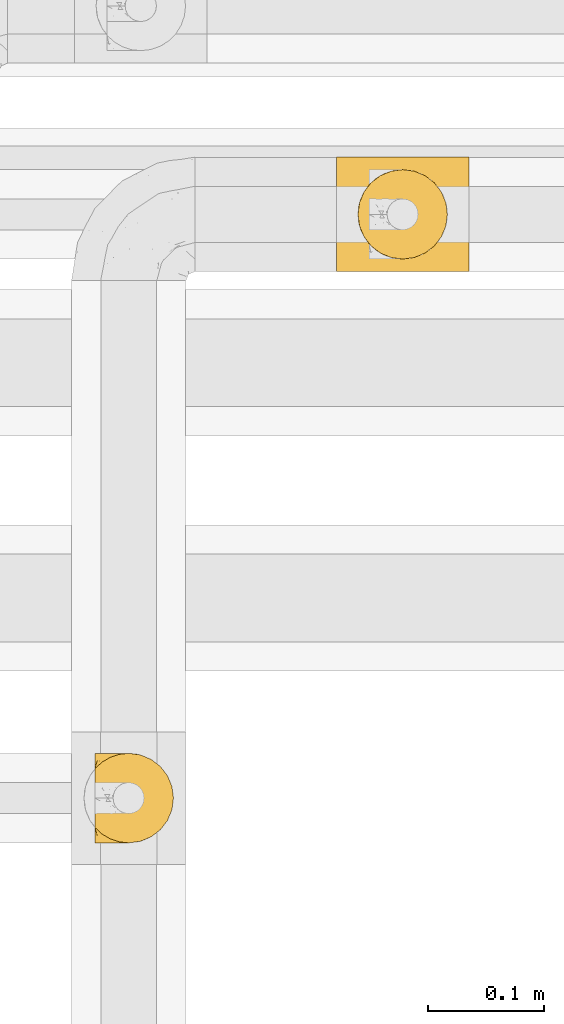
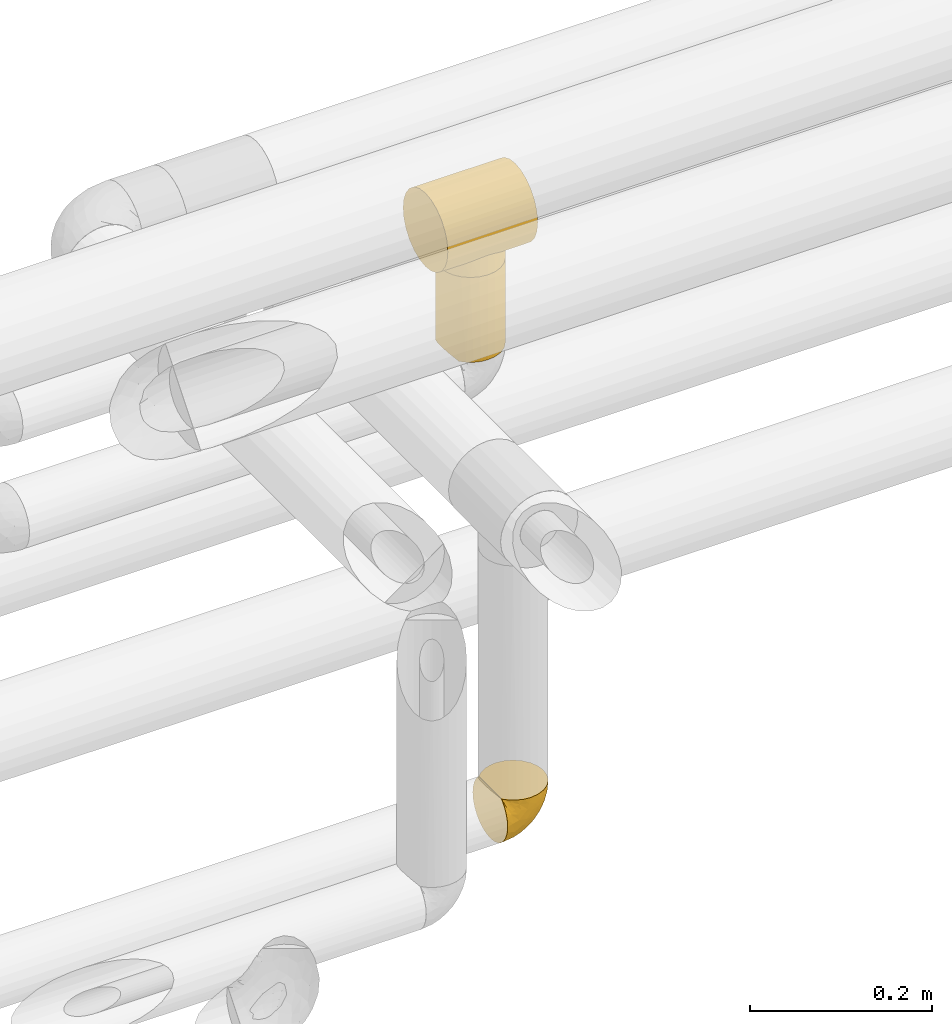
# One storey, part 365 of 827: 3 coverings.
"""IFC2X3 building model written with IfcOpenShell, lengths in millimetres."""

from ifc_helpers import new_model, entity, si_unit, converted_unit, derived_unit, direction, frame, origin, place, context, subcontext, project, spatial, faceted_brep, element, save


model = new_model("IFC2X3")

# Units and contexts
model_context = context("Model", 3, precision=0.01, world=origin(), true_north=direction((6.12303176911189e-17, 1.0)))
body_context = subcontext(model_context, "Body", "Model", "MODEL_VIEW")
ifc_project = project(units=[si_unit("LENGTHUNIT", "METRE", prefix="MILLI"), si_unit("AREAUNIT", "SQUARE_METRE"), si_unit("VOLUMEUNIT", "CUBIC_METRE"), converted_unit("PLANEANGLEUNIT", "DEGREE", entity("IfcRatioMeasure", 0.0174532925199433), si_unit("PLANEANGLEUNIT", "RADIAN"), dimensions=[0, 0, 0, 0, 0, 0, 0]), si_unit("MASSUNIT", "GRAM", prefix="KILO"), derived_unit("MASSDENSITYUNIT", [(si_unit("MASSUNIT", "GRAM", prefix="KILO"), 1), (si_unit("LENGTHUNIT", "METRE"), -3)]), derived_unit("MOMENTOFINERTIAUNIT", [(si_unit("LENGTHUNIT", "METRE"), 4)]), si_unit("TIMEUNIT", "SECOND"), si_unit("FREQUENCYUNIT", "HERTZ"), si_unit("THERMODYNAMICTEMPERATUREUNIT", "DEGREE_CELSIUS"), derived_unit("THERMALTRANSMITTANCEUNIT", [(si_unit("MASSUNIT", "GRAM", prefix="KILO"), 1), (si_unit("THERMODYNAMICTEMPERATUREUNIT", "KELVIN"), -1), (si_unit("TIMEUNIT", "SECOND"), -3)]), derived_unit("VOLUMETRICFLOWRATEUNIT", [(si_unit("LENGTHUNIT", "METRE"), 3), (si_unit("TIMEUNIT", "SECOND"), -1)]), derived_unit("MASSFLOWRATEUNIT", [(si_unit("MASSUNIT", "GRAM", prefix="KILO"), 1), (si_unit("TIMEUNIT", "SECOND"), -1)]), derived_unit("ROTATIONALFREQUENCYUNIT", [(si_unit("TIMEUNIT", "SECOND"), -1)]), si_unit("ELECTRICCURRENTUNIT", "AMPERE"), si_unit("ELECTRICVOLTAGEUNIT", "VOLT"), si_unit("POWERUNIT", "WATT"), si_unit("FORCEUNIT", "NEWTON", prefix="KILO"), si_unit("ILLUMINANCEUNIT", "LUX"), si_unit("LUMINOUSFLUXUNIT", "LUMEN"), si_unit("LUMINOUSINTENSITYUNIT", "CANDELA"), derived_unit("USERDEFINED", [(si_unit("MASSUNIT", "GRAM", prefix="KILO"), -1), (si_unit("LENGTHUNIT", "METRE"), -2), (si_unit("TIMEUNIT", "SECOND"), 3), (si_unit("LUMINOUSFLUXUNIT", "LUMEN"), 1)]), derived_unit("LINEARVELOCITYUNIT", [(si_unit("LENGTHUNIT", "METRE"), 1), (si_unit("TIMEUNIT", "SECOND"), -1)]), si_unit("PRESSUREUNIT", "PASCAL"), derived_unit("USERDEFINED", [(si_unit("LENGTHUNIT", "METRE"), -2), (si_unit("MASSUNIT", "GRAM", prefix="KILO"), 1), (si_unit("TIMEUNIT", "SECOND"), -2)]), derived_unit("LINEARFORCEUNIT", [(si_unit("MASSUNIT", "GRAM", prefix="KILO"), 1), (si_unit("LENGTHUNIT", "METRE"), 1), (si_unit("TIMEUNIT", "SECOND"), -2), (si_unit("LENGTHUNIT", "METRE"), -1)]), derived_unit("PLANARFORCEUNIT", [(si_unit("MASSUNIT", "GRAM", prefix="KILO"), 1), (si_unit("LENGTHUNIT", "METRE"), 1), (si_unit("TIMEUNIT", "SECOND"), -2), (si_unit("LENGTHUNIT", "METRE"), -2)])], contexts=[model_context])

# Site, building, storey
site_placement = place(None, origin())
site = spatial("IfcSite", under=ifc_project, at=site_placement, CompositionType="ELEMENT")
building_placement = place(site_placement, origin())
building = spatial("IfcBuilding", under=site, at=building_placement, CompositionType="ELEMENT")
storey_placement = place(building_placement, frame((0.0, 0.0, 28200.0)))
storey = spatial("IfcBuildingStorey", under=building, at=storey_placement, Name="08", CompositionType="ELEMENT", Elevation=28200.0)

# Coverings
covering_1_placement = place(storey_placement, frame((36825.03, 18896.41, 3227.5)))
element("IfcCovering", 1, at=covering_1_placement, inside=storey, Name=":ADSK_", ObjectType=":ADSK_", PredefinedType="INSULATION", context=body_context, shape_type="Brep", body=[
    faceted_brep([(77.09, 30.06, 115.39), (78.4, 40.0, 115.39), (77.09, 49.93, 115.39), (73.25, 59.2, 115.39), (67.15, 67.15, 115.39), (59.2, 73.25, 115.39), (49.93, 77.09, 115.39), (40.0, 78.4, 115.39), (30.06, 77.09, 115.39), (20.8, 73.25, 115.39), (12.84, 67.15, 115.39), (6.74, 59.2, 115.39), (2.9, 49.93, 115.39), (1.6, 40.0, 115.39), (2.9, 30.06, 115.39), (6.74, 20.8, 115.39), (12.84, 12.84, 115.39), (20.8, 6.74, 115.39), (30.06, 2.9, 115.39), (40.0, 1.6, 115.39), (49.93, 2.9, 115.39), (59.2, 6.74, 115.39), (67.15, 12.84, 115.39), (73.25, 20.8, 115.39), (78.4, 40.0, 1.6), (77.09, 30.06, 1.6), (73.25, 20.8, 1.6), (67.15, 12.84, 1.6), (59.2, 6.74, 1.6), (49.93, 2.9, 1.6), (40.0, 1.6, 1.6), (31.79, 2.48, 1.6), (23.98, 5.09, 1.6), (16.91, 9.31, 1.6), (10.9, 14.94, 1.6), (10.9, 65.05, 1.6), (16.91, 70.68, 1.6), (23.98, 74.9, 1.6), (31.79, 77.51, 1.6), (40.0, 78.4, 1.6), (49.93, 77.09, 1.6), (59.2, 73.25, 1.6), (67.15, 67.15, 1.6), (73.25, 59.2, 1.6), (77.09, 49.93, 1.6), (6.92, 59.51, 5.57), (4.0, 53.36, 8.5), (2.2, 46.78, 10.29), (1.6, 40.0, 10.9), (2.2, 33.21, 10.29), (4.0, 26.63, 8.5), (6.92, 20.48, 5.57)], [[[0, 1, 2, 3, 4, 5, 6, 7, 8, 9, 10, 11, 12, 13, 14, 15, 16, 17, 18, 19, 20, 21, 22, 23]], [[24, 25, 26, 27, 28, 29, 30, 31, 32, 33, 34, 35, 36, 37, 38, 39, 40, 41, 42, 43, 44]], [[29, 28, 21, 20]], [[30, 29, 20, 19]], [[28, 27, 22, 21]], [[0, 23, 26, 25]], [[1, 0, 25, 24]], [[27, 26, 23, 22]], [[2, 1, 24, 44]], [[3, 2, 44, 43]], [[43, 42, 4, 3]], [[6, 5, 41, 40]], [[7, 6, 40, 39]], [[42, 41, 5, 4]], [[7, 39, 38]], [[8, 38, 37]], [[9, 37, 36]], [[7, 38, 8]], [[8, 37, 9]], [[36, 10, 9]], [[36, 35, 10]], [[35, 45, 11]], [[46, 47, 12]], [[45, 46, 11]], [[11, 46, 12]], [[13, 12, 47]], [[48, 13, 47]], [[35, 11, 10]], [[49, 50, 14]], [[51, 34, 15]], [[50, 51, 15]], [[48, 49, 13]], [[13, 49, 14]], [[50, 15, 14]], [[34, 16, 15]], [[17, 33, 32]], [[18, 32, 31]], [[19, 31, 30]], [[16, 33, 17]], [[17, 32, 18]], [[31, 19, 18]], [[33, 16, 34]], [[47, 46, 45, 35, 34, 51, 50, 49, 48]]]),
])
covering_2_placement = place(storey_placement, frame((36808.02, 18885.66, 3342.89)))
element("IfcCovering", 2, at=covering_2_placement, inside=storey, Name=":ADSK_", ObjectType=":ADSK_", PredefinedType="INSULATION", context=body_context, shape_type="Brep", body=[
    faceted_brep([(0.0, 26.17, 99.57), (0.0, 38.02, 104.48), (0.0, 50.75, 106.15), (0.0, 63.47, 104.48), (0.0, 75.32, 99.57), (0.0, 85.5, 91.75), (0.0, 93.31, 81.58), (0.0, 98.22, 69.72), (0.0, 99.9, 57.0), (0.0, 98.22, 44.28), (0.0, 93.31, 32.43), (0.0, 85.5, 22.25), (0.0, 80.41, 18.34), (0.0, 75.32, 14.43), (0.0, 69.39, 11.98), (0.0, 63.47, 9.52), (0.0, 60.29, 9.11), (0.0, 57.11, 8.69), (0.0, 53.93, 8.27), (0.0, 50.75, 7.85), (0.0, 47.57, 8.27), (0.0, 44.38, 8.69), (0.0, 41.2, 9.11), (0.0, 38.02, 9.52), (0.0, 32.1, 11.98), (0.0, 26.17, 14.43), (0.0, 21.08, 18.34), (0.0, 15.99, 22.25), (0.0, 8.18, 32.43), (0.0, 3.27, 44.28), (0.0, 1.6, 57.0), (0.0, 3.27, 69.72), (0.0, 8.18, 81.58), (0.0, 15.99, 91.75), (114.0, 98.22, 69.72), (114.0, 93.31, 81.58), (114.0, 85.5, 91.75), (114.0, 75.32, 99.57), (114.0, 63.47, 104.48), (114.0, 50.75, 106.15), (114.0, 38.02, 104.48), (114.0, 26.17, 99.57), (114.0, 15.99, 91.75), (114.0, 8.18, 81.58), (114.0, 3.27, 69.72), (114.0, 1.6, 57.0), (114.0, 3.27, 44.28), (114.0, 8.18, 32.43), (114.0, 15.99, 22.25), (114.0, 21.08, 18.34), (114.0, 26.17, 14.43), (114.0, 32.1, 11.98), (114.0, 38.02, 9.52), (114.0, 41.2, 9.11), (114.0, 44.38, 8.69), (114.0, 47.57, 8.27), (114.0, 50.75, 7.85), (114.0, 53.93, 8.27), (114.0, 57.11, 8.69), (114.0, 60.29, 9.11), (114.0, 63.47, 9.52), (114.0, 69.39, 11.98), (114.0, 75.32, 14.43), (114.0, 80.41, 18.34), (114.0, 85.5, 22.25), (114.0, 93.31, 32.43), (114.0, 98.22, 44.28), (114.0, 99.9, 57.0), (80.91, 80.86, 18.16), (73.95, 85.26, 22.01), (86.77, 75.08, 14.3), (22.63, 67.99, 10.97), (65.92, 88.15, 25.11), (57.0, 89.2, 26.38), (48.08, 88.15, 25.11), (18.55, 50.75, 7.85), (95.45, 50.75, 7.85), (33.09, 80.86, 18.16), (40.05, 85.26, 22.01), (27.23, 75.08, 14.3), (91.37, 67.99, 10.97), (21.12, 63.86, 9.83), (94.39, 59.73, 8.68), (94.92, 55.24, 8.26), (92.88, 63.86, 9.83), (19.61, 59.73, 8.68), (19.08, 55.24, 8.26), (94.92, 46.25, 8.26), (92.88, 37.63, 9.83), (86.77, 26.41, 14.3), (94.39, 41.76, 8.68), (91.37, 33.5, 10.97), (21.12, 37.63, 9.83), (19.61, 41.76, 8.68), (19.08, 46.25, 8.26), (27.23, 26.41, 14.3), (22.63, 33.5, 10.97), (33.09, 20.63, 18.16), (80.91, 20.63, 18.16), (73.95, 16.23, 22.01), (65.92, 13.34, 25.11), (57.0, 12.3, 26.38), (40.05, 16.23, 22.01), (48.08, 13.34, 25.11), (57.0, 89.2, 0.0), (66.95, 87.89, 0.0), (76.22, 84.04, 0.0), (84.19, 77.93, 0.0), (90.3, 69.97, 0.0), (94.14, 60.7, 0.0), (95.45, 50.75, 0.0), (94.14, 40.79, 0.0), (90.3, 31.52, 0.0), (84.19, 23.56, 0.0), (76.23, 17.45, 0.0), (66.95, 13.61, 0.0), (57.0, 12.3, 0.0), (47.05, 13.61, 0.0), (37.77, 17.45, 0.0), (29.81, 23.56, 0.0), (23.7, 31.52, 0.0), (19.86, 40.79, 0.0), (18.55, 50.75, 0.0), (19.86, 60.7, 0.0), (23.7, 69.97, 0.0), (29.81, 77.93, 0.0), (37.77, 84.04, 0.0), (47.05, 87.89, 0.0)], [[[0, 1, 2, 3, 4, 5, 6, 7, 8, 9, 10, 11, 12, 13, 14, 15, 16, 17, 18, 19, 20, 21, 22, 23, 24, 25, 26, 27, 28, 29, 30, 31, 32, 33]], [[34, 35, 36, 37, 38, 39, 40, 41, 42, 43, 44, 45, 46, 47, 48, 49, 50, 51, 52, 53, 54, 55, 56, 57, 58, 59, 60, 61, 62, 63, 64, 65, 66, 67]], [[37, 36, 5, 4]], [[2, 39, 38, 3]], [[38, 37, 4, 3]], [[6, 35, 34, 7]], [[7, 34, 67, 8]], [[5, 36, 35, 6]], [[66, 9, 8, 67]], [[65, 10, 9, 66]], [[64, 68, 69]], [[63, 62, 70]], [[71, 15, 14]], [[69, 72, 64]], [[68, 64, 63]], [[64, 72, 65]], [[72, 73, 65]], [[74, 11, 10]], [[18, 75, 19]], [[76, 57, 56]], [[77, 11, 78]], [[78, 11, 74]], [[79, 12, 77]], [[74, 10, 73]], [[73, 10, 65]], [[70, 61, 80]], [[61, 70, 62]], [[80, 61, 60]], [[15, 71, 81]], [[82, 59, 58]], [[83, 57, 76]], [[84, 59, 82]], [[82, 58, 83]], [[83, 58, 57]], [[60, 84, 80]], [[17, 85, 86]], [[79, 13, 12]], [[59, 84, 60]], [[79, 14, 13]], [[14, 79, 71]], [[85, 17, 16]], [[77, 12, 11]], [[18, 17, 86]], [[15, 81, 16]], [[16, 81, 85]], [[75, 18, 86]], [[68, 63, 70]], [[54, 87, 55]], [[53, 52, 88]], [[76, 55, 87]], [[50, 89, 51]], [[54, 90, 87]], [[91, 51, 89]], [[91, 52, 51]], [[88, 90, 53]], [[92, 22, 93]], [[93, 21, 94]], [[75, 20, 19]], [[55, 76, 56]], [[20, 75, 94]], [[95, 25, 24]], [[90, 54, 53]], [[24, 23, 96]], [[95, 97, 26]], [[96, 23, 92]], [[89, 49, 98]], [[89, 50, 49]], [[94, 21, 20]], [[98, 48, 99]], [[48, 98, 49]], [[99, 48, 100]], [[52, 91, 88]], [[28, 47, 46, 29]], [[101, 100, 47]], [[47, 100, 48]], [[46, 45, 30, 29]], [[93, 22, 21]], [[102, 103, 27]], [[95, 24, 96]], [[26, 25, 95]], [[27, 97, 102]], [[103, 28, 27]], [[22, 92, 23]], [[101, 28, 103]], [[101, 47, 28]], [[97, 27, 26]], [[31, 44, 43, 32]], [[32, 43, 42, 33]], [[45, 44, 31, 30]], [[0, 41, 40, 1]], [[1, 40, 39, 2]], [[33, 42, 41, 0]], [[104, 105, 106, 107, 108, 109, 110, 111, 112, 113, 114, 115, 116, 117, 118, 119, 120, 121, 122, 123, 124, 125, 126, 127]], [[82, 110, 109]], [[80, 109, 108]], [[110, 82, 83, 76]], [[70, 80, 108]], [[109, 80, 84, 82]], [[108, 107, 70]], [[107, 106, 68]], [[106, 105, 69]], [[72, 105, 104]], [[68, 106, 69]], [[72, 69, 105]], [[73, 72, 104]], [[107, 68, 70]], [[74, 104, 127]], [[78, 127, 126]], [[73, 104, 74]], [[74, 127, 78]], [[126, 77, 78]], [[126, 125, 77]], [[79, 125, 124]], [[124, 123, 71]], [[122, 85, 123]], [[71, 79, 124]], [[122, 75, 86, 85]], [[123, 85, 81, 71]], [[125, 79, 77]], [[93, 122, 121]], [[96, 121, 120]], [[122, 93, 94, 75]], [[95, 96, 120]], [[121, 96, 92, 93]], [[120, 119, 95]], [[97, 119, 118]], [[118, 117, 102]], [[116, 103, 117]], [[97, 118, 102]], [[103, 102, 117]], [[101, 103, 116]], [[119, 97, 95]], [[100, 116, 115]], [[99, 115, 114]], [[101, 116, 100]], [[100, 115, 99]], [[114, 98, 99]], [[114, 113, 98]], [[89, 113, 112]], [[112, 111, 91]], [[110, 90, 111]], [[91, 89, 112]], [[110, 76, 87, 90]], [[111, 90, 88, 91]], [[113, 89, 98]]]),
])
covering_3_placement = place(storey_placement, frame((36598.95, 18394.86, 2960.12)))
element("IfcCovering", 3, at=covering_3_placement, inside=storey, Name=":ADSK_", ObjectType=":ADSK_", PredefinedType="INSULATION", context=body_context, shape_type="Brep", body=[
    faceted_brep([(1.6, 74.68, 23.36), (1.6, 70.1, 16.07), (1.6, 64.01, 9.98), (1.6, 56.72, 5.4), (1.6, 48.6, 2.56), (1.6, 40.05, 1.6), (1.6, 31.49, 2.56), (1.6, 23.36, 5.41), (1.6, 16.07, 9.99), (1.6, 9.98, 16.08), (1.6, 5.4, 23.37), (1.6, 2.56, 31.49), (1.6, 1.6, 40.05), (1.6, 2.46, 48.15), (1.6, 5.01, 55.88), (1.6, 9.13, 62.9), (1.6, 14.62, 68.89), (1.6, 16.82, 68.89), (1.6, 18.56, 68.89), (1.6, 20.52, 68.89), (1.6, 22.49, 68.89), (1.6, 24.46, 68.89), (1.6, 26.42, 68.89), (1.6, 28.39, 68.89), (1.6, 30.36, 68.89), (1.6, 32.55, 68.89), (1.6, 34.75, 68.89), (1.6, 36.94, 68.89), (1.6, 39.13, 68.89), (1.6, 41.33, 68.89), (1.6, 43.52, 68.89), (1.6, 45.72, 68.89), (1.6, 47.91, 68.89), (1.6, 50.11, 68.89), (1.6, 52.3, 68.89), (1.6, 54.49, 68.89), (1.6, 56.69, 68.89), (1.6, 58.88, 68.89), (1.6, 61.08, 68.89), (1.6, 63.27, 68.89), (1.6, 65.47, 68.89), (1.6, 70.97, 62.89), (1.6, 75.09, 55.86), (1.6, 77.64, 48.13), (1.6, 78.5, 40.05), (1.6, 77.53, 31.49), (1.85, 14.62, 69.15), (7.85, 9.12, 69.15), (14.87, 5.0, 69.15), (22.6, 2.46, 69.15), (30.7, 1.6, 69.15), (40.65, 2.91, 69.15), (49.92, 6.75, 69.15), (57.88, 12.86, 69.15), (63.99, 20.82, 69.15), (67.84, 30.09, 69.15), (69.15, 40.05, 69.15), (67.84, 50.0, 69.15), (63.99, 59.27, 69.15), (57.88, 67.23, 69.15), (49.92, 73.34, 69.15), (40.65, 77.19, 69.15), (30.7, 78.5, 69.15), (22.6, 77.63, 69.15), (14.87, 75.09, 69.15), (7.85, 70.97, 69.15), (1.85, 65.47, 69.15), (1.85, 63.27, 69.15), (1.85, 62.29, 69.15), (1.85, 60.7, 69.15), (1.85, 59.11, 69.15), (1.85, 57.52, 69.15), (1.85, 55.93, 69.15), (1.85, 54.34, 69.15), (1.85, 52.76, 69.15), (1.85, 51.17, 69.15), (1.85, 49.58, 69.15), (1.85, 47.99, 69.15), (1.85, 46.4, 69.15), (1.85, 44.81, 69.15), (1.85, 43.22, 69.15), (1.85, 41.63, 69.15), (1.85, 40.05, 69.15), (1.85, 38.46, 69.15), (1.85, 36.87, 69.15), (1.85, 35.28, 69.15), (1.85, 33.69, 69.15), (1.85, 32.1, 69.15), (1.85, 30.51, 69.15), (1.85, 28.92, 69.15), (1.85, 27.33, 69.15), (1.85, 25.37, 69.15), (1.85, 23.4, 69.15), (1.85, 21.21, 69.15), (1.85, 19.01, 69.15), (1.85, 16.82, 69.15), (1.77, 42.32, 68.96), (1.78, 44.02, 68.97), (1.77, 47.13, 68.97), (1.77, 48.74, 68.97), (1.76, 23.57, 68.95), (1.77, 25.13, 68.96), (1.79, 61.34, 68.98), (1.78, 22.02, 68.97), (1.78, 29.72, 68.97), (1.78, 56.73, 68.98), (1.78, 55.14, 68.97), (1.78, 37.66, 68.97), (1.74, 64.12, 68.94), (1.78, 28.13, 68.98), (1.78, 26.62, 68.98), (1.77, 31.46, 68.96), (1.78, 16.16, 68.97), (1.78, 39.16, 68.98), (1.78, 50.37, 68.98), (1.77, 17.69, 68.97), (1.77, 19.17, 68.96), (1.77, 62.78, 68.97), (1.78, 58.35, 68.97), (1.78, 45.53, 68.98), (1.77, 59.91, 68.96), (1.77, 65.47, 68.97), (1.72, 65.47, 68.94), (1.66, 65.47, 68.92), (1.77, 14.62, 68.97), (1.8, 14.62, 69.02), (1.82, 14.62, 69.08), (1.79, 20.59, 68.98), (1.78, 32.99, 68.97), (1.79, 34.48, 68.98), (1.78, 51.91, 68.97), (1.82, 65.47, 69.08), (1.8, 65.47, 69.02), (1.76, 53.48, 68.96), (1.66, 14.62, 68.92), (1.72, 14.62, 68.94), (1.78, 40.77, 68.97), (1.77, 35.97, 68.96), (9.41, 7.84, 67.02), (17.65, 3.53, 63.33), (7.41, 8.32, 64.61), (15.21, 2.19, 51.4), (7.41, 3.53, 53.1), (16.15, 1.6, 43.94), (28.75, 1.6, 61.87), (13.67, 4.57, 61.54), (12.79, 3.96, 57.95), (19.18, 2.28, 56.12), (29.16, 1.6, 63.4), (9.04, 7.69, 65.41), (5.74, 8.32, 63.04), (3.72, 7.84, 61.33), (8.87, 1.6, 41.99), (21.47, 1.6, 49.27), (26.8, 1.6, 54.6), (9.53, 4.34, 56.6), (7.34, 1.6, 41.58), (37.63, 29.63, 13.72), (17.92, 27.34, 5.82), (27.45, 40.05, 6.74), (37.01, 2.39, 58.82), (34.22, 2.43, 51.58), (45.87, 9.07, 42.09), (56.57, 16.64, 46.12), (52.31, 9.54, 55.56), (42.07, 4.52, 52.38), (44.74, 4.52, 61.54), (21.49, 7.49, 23.76), (11.02, 7.49, 20.5), (15.64, 12.85, 14.64), (26.02, 2.35, 41.77), (36.59, 22.66, 16.28), (65.49, 32.9, 49.4), (63.99, 25.33, 52.34), (15.2, 40.05, 4.3), (60.27, 16.64, 58.67), (45.25, 19.99, 25.26), (35.21, 16.37, 20.17), (22.52, 3.26, 34.7), (12.03, 3.75, 28.67), (13.32, 19.58, 8.62), (35.9, 7.5, 33.37), (33.87, 4.04, 41.35), (25.73, 13.94, 17.15), (26.34, 19.58, 12.68), (46.78, 28.21, 21.47), (59.54, 24.75, 41.11), (60.18, 31.42, 37.53), (53.93, 26.2, 30.64), (53.36, 33.36, 26.66), (49.36, 40.05, 21.38), (38.4, 40.05, 14.06), (66.44, 40.05, 55.54), (50.09, 16.14, 35.17), (41.08, 12.85, 29.04), (31.14, 10.47, 24.34), (28.19, 6.49, 29.33), (64.0, 40.05, 43.3), (56.68, 40.05, 32.34), (43.9, 75.57, 57.75), (65.46, 47.37, 49.41), (52.22, 52.91, 27.85), (37.61, 50.46, 13.7), (15.64, 67.23, 14.63), (13.31, 60.5, 8.61), (50.02, 70.55, 48.85), (59.28, 63.45, 54.13), (53.05, 62.61, 37.84), (21.48, 72.6, 23.75), (11.01, 72.6, 20.49), (12.03, 76.34, 28.66), (41.02, 59.34, 20.83), (35.39, 77.76, 55.15), (26.8, 78.5, 54.6), (28.75, 78.5, 61.87), (7.34, 78.5, 41.58), (65.81, 53.16, 57.58), (53.28, 70.55, 59.91), (59.8, 48.88, 36.94), (61.82, 54.76, 45.72), (17.91, 52.74, 5.82), (41.4, 71.93, 37.91), (40.48, 75.79, 50.18), (26.34, 60.5, 12.67), (31.68, 77.86, 49.29), (27.68, 77.64, 42.64), (16.15, 78.5, 43.94), (21.47, 78.5, 49.27), (28.05, 67.23, 19.45), (22.54, 76.82, 34.7), (8.87, 78.5, 41.99), (37.3, 77.8, 62.29), (41.07, 67.23, 29.01), (32.24, 73.2, 31.47), (47.4, 67.66, 37.18), (35.77, 75.99, 43.45), (17.65, 76.57, 63.33), (11.06, 73.21, 67.23), (8.55, 71.93, 66.07), (6.63, 71.07, 65.22), (12.77, 75.09, 61.99), (12.79, 76.13, 57.95), (7.41, 76.57, 53.09), (18.97, 77.69, 56.84), (3.72, 72.26, 61.33), (5.76, 71.77, 63.06), (15.21, 77.9, 51.41), (9.52, 75.75, 56.61)], [[[0, 1, 2, 3, 4, 5, 6, 7, 8, 9, 10, 11, 12, 13, 14, 15, 16, 17, 18, 19, 20, 21, 22, 23, 24, 25, 26, 27, 28, 29, 30, 31, 32, 33, 34, 35, 36, 37, 38, 39, 40, 41, 42, 43, 44, 45]], [[46, 47, 48, 49, 50, 51, 52, 53, 54, 55, 56, 57, 58, 59, 60, 61, 62, 63, 64, 65, 66, 67, 68, 69, 70, 71, 72, 73, 74, 75, 76, 77, 78, 79, 80, 81, 82, 83, 84, 85, 86, 87, 88, 89, 90, 91, 92, 93, 94, 95]], [[96, 97, 30]], [[98, 77, 99]], [[100, 101, 21]], [[69, 68, 102]], [[20, 19, 103]], [[24, 23, 104]], [[20, 103, 100]], [[72, 105, 106]], [[84, 83, 107]], [[89, 88, 104]], [[108, 67, 66]], [[109, 110, 90]], [[111, 25, 24]], [[112, 17, 16]], [[82, 113, 83]], [[109, 23, 22]], [[114, 76, 75]], [[105, 36, 106]], [[104, 111, 24]], [[18, 115, 116]], [[97, 96, 80]], [[67, 108, 117]], [[105, 71, 118]], [[31, 97, 119]], [[102, 120, 69]], [[108, 121, 122, 123, 40]], [[112, 95, 115]], [[17, 115, 18]], [[94, 116, 115]], [[117, 68, 67]], [[38, 117, 39]], [[112, 124, 125, 126, 46]], [[17, 112, 115]], [[70, 120, 118]], [[39, 117, 108]], [[120, 38, 37]], [[120, 37, 118]], [[120, 70, 69]], [[116, 94, 127]], [[128, 86, 129]], [[117, 38, 102]], [[74, 130, 75]], [[99, 33, 32]], [[115, 95, 94]], [[39, 108, 40]], [[108, 66, 131, 132, 121]], [[105, 72, 71]], [[118, 37, 36]], [[71, 70, 118]], [[35, 106, 36]], [[36, 105, 118]], [[35, 133, 106]], [[74, 73, 133]], [[106, 133, 73]], [[99, 114, 33]], [[133, 35, 34]], [[73, 72, 106]], [[95, 112, 46]], [[112, 16, 134, 135, 124]], [[130, 114, 75]], [[99, 76, 114]], [[114, 130, 33]], [[34, 33, 130]], [[78, 77, 98]], [[98, 119, 78]], [[130, 133, 34]], [[133, 130, 74]], [[79, 97, 80]], [[98, 99, 32]], [[98, 32, 31]], [[77, 76, 99]], [[97, 79, 119]], [[136, 96, 29]], [[30, 97, 31]], [[136, 29, 28]], [[81, 80, 96]], [[29, 96, 30]], [[31, 119, 98]], [[119, 79, 78]], [[96, 136, 81]], [[82, 81, 136]], [[113, 107, 83]], [[84, 107, 137]], [[107, 27, 137]], [[113, 28, 107]], [[27, 107, 28]], [[85, 84, 137]], [[137, 27, 26]], [[113, 136, 28]], [[136, 113, 82]], [[109, 89, 104]], [[86, 85, 129]], [[89, 109, 90]], [[111, 87, 128]], [[26, 129, 137]], [[88, 111, 104]], [[25, 111, 128]], [[22, 110, 109]], [[23, 109, 104]], [[110, 91, 90]], [[100, 92, 101]], [[110, 22, 101]], [[91, 110, 101]], [[116, 19, 18]], [[111, 88, 87]], [[127, 103, 19]], [[25, 128, 26]], [[86, 128, 87]], [[128, 129, 26]], [[137, 129, 85]], [[120, 102, 38]], [[117, 102, 68]], [[91, 101, 92]], [[21, 101, 22]], [[93, 92, 103]], [[100, 21, 20]], [[100, 103, 92]], [[127, 93, 103]], [[93, 127, 94]], [[116, 127, 19]], [[126, 138, 47]], [[48, 138, 139]], [[140, 125, 124]], [[141, 142, 143]], [[144, 49, 139]], [[145, 140, 146]], [[48, 139, 49]], [[139, 145, 147]], [[49, 144, 148, 50]], [[126, 125, 149]], [[14, 13, 142]], [[150, 146, 140]], [[149, 140, 145]], [[151, 150, 135]], [[151, 14, 142]], [[16, 15, 134]], [[13, 152, 142]], [[124, 150, 140]], [[141, 143, 153]], [[14, 151, 15]], [[15, 151, 134]], [[47, 46, 126]], [[139, 154, 144]], [[138, 48, 47]], [[125, 140, 149]], [[135, 134, 151]], [[146, 155, 141]], [[145, 146, 147]], [[149, 139, 138]], [[147, 153, 154]], [[147, 146, 141]], [[139, 147, 154]], [[139, 149, 145]], [[149, 138, 126]], [[147, 141, 153]], [[146, 150, 155]], [[151, 155, 150]], [[142, 141, 155]], [[13, 12, 156, 152]], [[152, 143, 142]], [[151, 142, 155]], [[150, 124, 135]], [[157, 158, 159]], [[160, 154, 161]], [[162, 163, 164]], [[165, 166, 160]], [[167, 168, 169]], [[153, 170, 161]], [[156, 12, 11]], [[158, 157, 171]], [[172, 55, 173]], [[158, 6, 174]], [[175, 54, 53]], [[52, 166, 164]], [[52, 164, 53]], [[54, 175, 173]], [[166, 52, 51]], [[176, 177, 171]], [[178, 143, 179]], [[156, 11, 179]], [[8, 7, 180]], [[169, 9, 8]], [[179, 143, 152, 156]], [[179, 11, 10]], [[168, 179, 10]], [[181, 162, 182]], [[179, 167, 178]], [[183, 184, 177]], [[183, 169, 184]], [[176, 171, 185]], [[172, 186, 187]], [[158, 7, 6]], [[159, 158, 174]], [[184, 180, 158]], [[54, 173, 55]], [[180, 169, 8]], [[188, 189, 187]], [[9, 168, 10]], [[186, 188, 187]], [[190, 157, 159, 191]], [[55, 172, 192]], [[176, 193, 194]], [[161, 170, 182]], [[162, 164, 165]], [[175, 164, 163]], [[51, 50, 148]], [[167, 195, 196]], [[178, 182, 170]], [[6, 5, 174]], [[158, 180, 7]], [[169, 180, 184]], [[169, 168, 9]], [[179, 168, 167]], [[182, 162, 165]], [[162, 194, 193]], [[161, 165, 160]], [[195, 181, 196]], [[192, 172, 197]], [[192, 56, 55]], [[189, 190, 198]], [[198, 197, 187]], [[172, 187, 197]], [[185, 189, 188]], [[198, 187, 189]], [[186, 172, 173]], [[173, 163, 186]], [[193, 186, 163]], [[176, 185, 188]], [[185, 157, 190]], [[188, 186, 193]], [[177, 176, 194]], [[188, 193, 176]], [[162, 193, 163]], [[195, 177, 194]], [[171, 177, 184]], [[181, 195, 194]], [[183, 167, 169]], [[162, 181, 194]], [[196, 182, 178]], [[158, 171, 184]], [[171, 157, 185]], [[177, 195, 183]], [[167, 183, 195]], [[182, 196, 181]], [[178, 170, 143]], [[178, 167, 196]], [[164, 175, 53]], [[173, 175, 163]], [[160, 51, 148]], [[164, 166, 165]], [[51, 160, 166]], [[160, 148, 144, 154]], [[153, 161, 154]], [[182, 165, 161]], [[190, 189, 185]], [[143, 170, 153]], [[60, 199, 61]], [[197, 200, 192]], [[201, 190, 202]], [[200, 57, 192]], [[203, 204, 2]], [[205, 206, 207]], [[208, 209, 210]], [[211, 207, 201]], [[212, 213, 214]], [[45, 215, 210]], [[216, 206, 58]], [[45, 44, 215]], [[59, 217, 60]], [[60, 217, 199]], [[0, 45, 210]], [[218, 201, 219]], [[202, 159, 220]], [[205, 221, 222]], [[223, 204, 203]], [[1, 203, 2]], [[57, 200, 216]], [[220, 3, 204]], [[220, 174, 4]], [[1, 0, 209]], [[212, 224, 213]], [[225, 226, 227]], [[228, 223, 203]], [[208, 210, 229]], [[210, 226, 229]], [[3, 220, 4]], [[58, 206, 59]], [[209, 203, 1]], [[202, 220, 223]], [[228, 203, 208]], [[202, 211, 201]], [[3, 2, 204]], [[202, 190, 191, 159]], [[210, 215, 230, 226]], [[199, 212, 231]], [[232, 233, 221]], [[233, 208, 229]], [[207, 206, 219]], [[217, 206, 205]], [[227, 224, 225]], [[233, 232, 228]], [[201, 207, 219]], [[234, 232, 221]], [[218, 219, 200]], [[202, 223, 211]], [[174, 220, 159]], [[174, 5, 4]], [[61, 231, 62]], [[220, 204, 223]], [[210, 209, 0]], [[203, 209, 208]], [[225, 233, 229]], [[224, 227, 213]], [[221, 233, 235]], [[57, 56, 192]], [[198, 218, 197]], [[200, 219, 216]], [[201, 198, 190]], [[197, 218, 200]], [[198, 201, 218]], [[206, 216, 219]], [[58, 57, 216]], [[231, 212, 214]], [[222, 212, 199]], [[228, 211, 223]], [[207, 211, 232]], [[62, 231, 214]], [[199, 231, 61]], [[233, 228, 208]], [[211, 228, 232]], [[222, 221, 235]], [[234, 205, 207]], [[206, 217, 59]], [[199, 217, 205]], [[205, 222, 199]], [[224, 222, 235]], [[222, 224, 212]], [[224, 235, 225]], [[233, 225, 235]], [[226, 225, 229]], [[205, 234, 221]], [[207, 232, 234]], [[63, 214, 236]], [[214, 213, 236]], [[214, 63, 62]], [[237, 236, 238]], [[238, 132, 131]], [[236, 237, 64]], [[239, 240, 241]], [[63, 236, 64]], [[131, 66, 65]], [[237, 131, 65]], [[242, 230, 43]], [[237, 65, 64]], [[239, 121, 132]], [[42, 242, 43]], [[241, 240, 243]], [[41, 123, 244]], [[43, 230, 215, 44]], [[244, 122, 245]], [[227, 246, 243]], [[241, 247, 245]], [[121, 239, 245]], [[41, 40, 123]], [[132, 238, 239]], [[244, 42, 41]], [[131, 237, 238]], [[240, 239, 238]], [[245, 239, 241]], [[247, 241, 246]], [[247, 244, 245]], [[238, 236, 240]], [[243, 236, 213]], [[236, 243, 240]], [[227, 226, 246]], [[243, 213, 227]], [[242, 246, 226]], [[243, 246, 241]], [[246, 242, 247]], [[244, 247, 242]], [[242, 226, 230]], [[42, 244, 242]], [[122, 244, 123]], [[122, 121, 245]]]),
])

save(model, "model.ifc")
